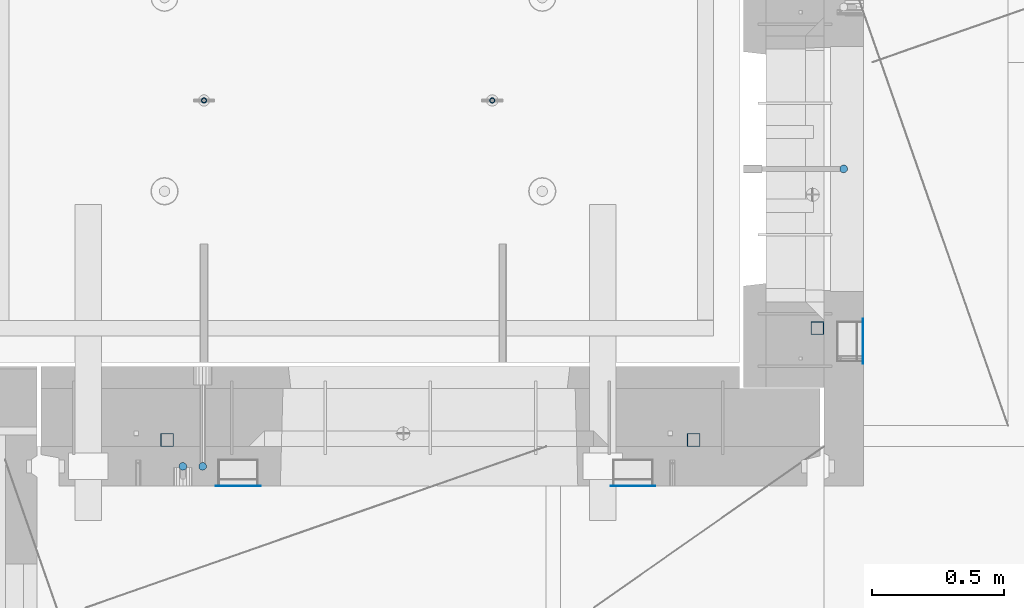
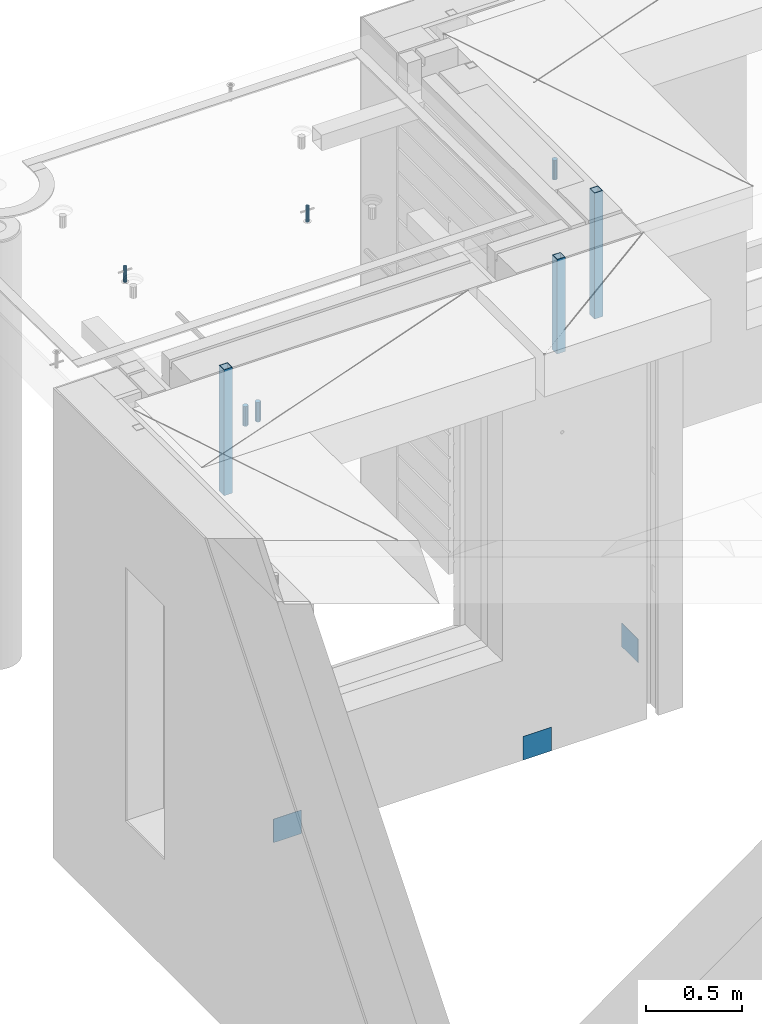
# One storey, part 27 of 352: 11 columns, 11 elements without a shape of their own.
"""IFC2X3 building model written with IfcOpenShell, lengths in millimetres."""

from ifc_helpers import new_model, si_unit, frame, origin_with_axes, place, context, subcontext, project, spatial, faceted_brep, material, type_object, element, aggregate, save


model = new_model("IFC2X3")

# Units and contexts
model_context = context("Model", 3, precision=1e-05, world=origin_with_axes())
body_context = subcontext(model_context, "Body", "Model", "MODEL_VIEW")
ifc_project = project(units=[si_unit("LENGTHUNIT", "METRE", prefix="MILLI"), si_unit("AREAUNIT", "SQUARE_METRE"), si_unit("VOLUMEUNIT", "CUBIC_METRE"), si_unit("MASSUNIT", "GRAM", prefix="KILO"), si_unit("TIMEUNIT", "SECOND"), si_unit("PLANEANGLEUNIT", "RADIAN"), si_unit("SOLIDANGLEUNIT", "STERADIAN"), si_unit("THERMODYNAMICTEMPERATUREUNIT", "DEGREE_CELSIUS"), si_unit("LUMINOUSINTENSITYUNIT", "LUMEN")], contexts=[model_context])

# Site, building, storey
site_placement = place(None, origin_with_axes())
site = spatial("IfcSite", under=ifc_project, at=site_placement, CompositionType="ELEMENT")
building_placement = place(site_placement, origin_with_axes())
building = spatial("IfcBuilding", under=site, at=building_placement, CompositionType="ELEMENT")
storey_placement = place(building_placement, origin_with_axes())
storey = spatial("IfcBuildingStorey", under=building, at=storey_placement, Name="6", CompositionType="ELEMENT", Elevation=0.0)

# Assembly, columns
assembly_1_placement = place(storey_placement, origin_with_axes())
assembly_1 = element("IfcElementAssembly", 1, at=assembly_1_placement, inside=storey, AssemblyPlace="NOTDEFINED", PredefinedType="REINFORCEMENT_UNIT")
ifc_material_1 = material()
column_type_1 = type_object("IfcColumnType", Name="D30", PredefinedType="NOTDEFINED")
column_1_placement = place(assembly_1_placement, frame((8555.00000000836, 20504.9951872276, 99407.5), z_axis=(0.0, 1.0, 0.0), x_axis=(0.0, 0.0, 1.0)))
column_1 = element("IfcColumn", 2, at=column_1_placement, type_object=column_type_1, material=ifc_material_1, ObjectType="D30", context=body_context, shape_type="Brep", body=[
    faceted_brep([(0.0, -15.0, 0.0), (0.0, -12.9903810567666, -7.5), (125.0, -12.9903810567666, -7.5), (125.0, -15.0, 0.0), (0.0, -7.5, -12.9903810567666), (125.0, -7.5, -12.9903810567666), (0.0, 0.0, -15.0), (125.0, 0.0, -15.0), (0.0, 7.5, -12.9903810567666), (125.0, 7.5, -12.9903810567666), (0.0, 12.9903810567666, -7.5), (125.0, 12.9903810567666, -7.5), (0.0, 15.0, 0.0), (125.0, 15.0, 0.0), (0.0, 12.9903810567666, 7.5), (125.0, 12.9903810567666, 7.5), (0.0, 7.5, 12.9903810567666), (125.0, 7.5, 12.9903810567666), (0.0, 0.0, 15.0), (125.0, 0.0, 15.0), (0.0, -7.5, 12.9903810567666), (125.0, -7.5, 12.9903810567666), (0.0, -12.9903810567666, 7.5), (125.0, -12.9903810567666, 7.5)], [[[0, 1, 2, 3]], [[1, 4, 5, 2]], [[4, 6, 7, 5]], [[6, 8, 9, 7]], [[8, 10, 11, 9]], [[10, 12, 13, 11]], [[12, 14, 15, 13]], [[14, 16, 17, 15]], [[16, 18, 19, 17]], [[18, 20, 21, 19]], [[20, 22, 23, 21]], [[22, 0, 3, 23]], [[5, 7, 9, 11, 13, 15, 17, 19, 21, 23, 3, 2]], [[22, 20, 18, 16, 14, 12, 10, 8, 6, 4, 1, 0]]]),
])
column_2_placement = place(assembly_1_placement, frame((8630.00733346229, 20504.9951872205, 99407.5), z_axis=(0.0, -1.0, 0.0), x_axis=(0.0, 0.0, 1.0)))
column_2 = element("IfcColumn", 3, at=column_2_placement, type_object=column_type_1, material=ifc_material_1, ObjectType="D30", context=body_context, shape_type="Brep", body=[
    faceted_brep([(0.0, -15.0, 0.0), (0.0, -12.9903810567666, -7.5), (125.0, -12.9903810567666, -7.5), (125.0, -15.0, 0.0), (0.0, -7.5, -12.9903810567666), (125.0, -7.5, -12.9903810567666), (0.0, 0.0, -15.0), (125.0, 0.0, -15.0), (0.0, 7.5, -12.9903810567666), (125.0, 7.5, -12.9903810567666), (0.0, 12.9903810567666, -7.5), (125.0, 12.9903810567666, -7.5), (0.0, 15.0, 0.0), (125.0, 15.0, 0.0), (0.0, 12.9903810567666, 7.5), (125.0, 12.9903810567666, 7.5), (0.0, 7.5, 12.9903810567666), (125.0, 7.5, 12.9903810567666), (0.0, 0.0, 15.0), (125.0, 0.0, 15.0), (0.0, -7.5, 12.9903810567666), (125.0, -7.5, 12.9903810567666), (0.0, -12.9903810567666, 7.5), (125.0, -12.9903810567666, 7.5)], [[[0, 1, 2, 3]], [[1, 4, 5, 2]], [[4, 6, 7, 5]], [[6, 8, 9, 7]], [[8, 10, 11, 9]], [[10, 12, 13, 11]], [[12, 14, 15, 13]], [[14, 16, 17, 15]], [[16, 18, 19, 17]], [[18, 20, 21, 19]], [[20, 22, 23, 21]], [[22, 0, 3, 23]], [[5, 7, 9, 11, 13, 15, 17, 19, 21, 23, 3, 2]], [[22, 20, 18, 16, 14, 12, 10, 8, 6, 4, 1, 0]]]),
])

# Assembly, column
assembly_2_placement = place(storey_placement, origin_with_axes())
assembly_2 = element("IfcElementAssembly", 4, at=assembly_2_placement, inside=storey, AssemblyPlace="NOTDEFINED", PredefinedType="REINFORCEMENT_UNIT")
column_3_placement = place(assembly_2_placement, frame((11064.9999999907, 21634.9982799657, 99407.5), z_axis=(1.0, 0.0, 0.0), x_axis=(0.0, 0.0, 1.0)))
column_3 = element("IfcColumn", 5, at=column_3_placement, type_object=column_type_1, material=ifc_material_1, ObjectType="D30", context=body_context, shape_type="Brep", body=[
    faceted_brep([(0.0, -15.0, 0.0), (0.0, -12.9903810567666, -7.5), (125.0, -12.9903810567666, -7.5), (125.0, -15.0, 0.0), (0.0, -7.5, -12.9903810567666), (125.0, -7.5, -12.9903810567666), (0.0, 0.0, -15.0), (125.0, 0.0, -15.0), (0.0, 7.5, -12.9903810567666), (125.0, 7.5, -12.9903810567666), (0.0, 12.9903810567666, -7.5), (125.0, 12.9903810567666, -7.5), (0.0, 15.0, 0.0), (125.0, 15.0, 0.0), (0.0, 12.9903810567666, 7.5), (125.0, 12.9903810567666, 7.5), (0.0, 7.5, 12.9903810567666), (125.0, 7.5, 12.9903810567666), (0.0, 0.0, 15.0), (125.0, 0.0, 15.0), (0.0, -7.5, 12.9903810567666), (125.0, -7.5, 12.9903810567666), (0.0, -12.9903810567666, 7.5), (125.0, -12.9903810567666, 7.5)], [[[0, 1, 2, 3]], [[1, 4, 5, 2]], [[4, 6, 7, 5]], [[6, 8, 9, 7]], [[8, 10, 11, 9]], [[10, 12, 13, 11]], [[12, 14, 15, 13]], [[14, 16, 17, 15]], [[16, 18, 19, 17]], [[18, 20, 21, 19]], [[20, 22, 23, 21]], [[22, 0, 3, 23]], [[5, 7, 9, 11, 13, 15, 17, 19, 21, 23, 3, 2]], [[22, 20, 18, 16, 14, 12, 10, 8, 6, 4, 1, 0]]]),
])

assembly_3_placement = place(assembly_1_placement, origin_with_axes())
assembly_3 = element("IfcElementAssembly", 6, at=assembly_3_placement, Name="Steel Assembly", AssemblyPlace="NOTDEFINED", PredefinedType="NOTDEFINED")
ifc_material_2 = material(Name="Undefined")
column_type_2 = type_object("IfcColumnType", PredefinedType="NOTDEFINED")
column_4_placement = place(assembly_3_placement, frame((10265.0, 20430.9951872214, 96755.0), z_axis=(0.0, -1.0, 0.0), x_axis=(0.0, 0.0, 1.0)))
column_4 = element("IfcColumn", 7, at=column_4_placement, type_object=column_type_2, material=ifc_material_2, Name="SPK2", context=body_context, shape_type="Brep", body=[
    faceted_brep([(0.0, 85.0, -1.0), (0.0, 85.0, 1.0), (150.0, 85.0, 1.0), (150.0, 85.0, -1.0), (0.0, -85.0, 1.0), (150.0, -85.0, 1.0), (0.0, -85.0, -1.0), (150.0, -85.0, -1.0)], [[[0, 1, 2, 3]], [[1, 4, 5, 2]], [[4, 6, 7, 5]], [[6, 0, 3, 7]], [[5, 7, 3, 2]], [[6, 4, 1, 0]]]),
])
aggregate(assembly_3, [column_4])

assembly_4_placement = place(assembly_1_placement, origin_with_axes())
assembly_4 = element("IfcElementAssembly", 8, at=assembly_4_placement, Name="Steel Assembly", AssemblyPlace="NOTDEFINED", PredefinedType="NOTDEFINED")
column_5_placement = place(assembly_4_placement, frame((8765.0, 20430.9951872214, 96755.0), z_axis=(0.0, -1.0, 0.0), x_axis=(0.0, 0.0, 1.0)))
column_5 = element("IfcColumn", 9, at=column_5_placement, type_object=column_type_2, material=ifc_material_2, Name="SPK2", context=body_context, shape_type="Brep", body=[
    faceted_brep([(0.0, 85.0, -1.0), (0.0, 85.0, 1.0), (150.0, 85.0, 1.0), (150.0, 85.0, -1.0), (0.0, -85.0, 1.0), (150.0, -85.0, 1.0), (0.0, -85.0, -1.0), (150.0, -85.0, -1.0)], [[[0, 1, 2, 3]], [[1, 4, 5, 2]], [[4, 6, 7, 5]], [[6, 0, 3, 7]], [[5, 7, 3, 2]], [[6, 4, 1, 0]]]),
])
aggregate(assembly_4, [column_5])

assembly_5_placement = place(assembly_2_placement, origin_with_axes())
assembly_5 = element("IfcElementAssembly", 10, at=assembly_5_placement, Name="Steel Assembly", AssemblyPlace="NOTDEFINED", PredefinedType="NOTDEFINED")
column_6_placement = place(assembly_5_placement, frame((11139.0000000031, 20979.9951872276, 96754.9999999969), z_axis=(1.0, 0.0, 0.0), x_axis=(0.0, 0.0, 1.0)))
column_6 = element("IfcColumn", 11, at=column_6_placement, type_object=column_type_2, material=ifc_material_2, Name="SPK2", context=body_context, shape_type="Brep", body=[
    faceted_brep([(0.0, 85.0, -1.0), (0.0, 85.0, 1.0), (150.0, 85.0, 1.0), (150.0, 85.0, -1.0), (0.0, -85.0, 1.0), (150.0, -85.0, 1.0), (0.0, -85.0, -1.0), (150.0, -85.0, -1.0)], [[[0, 1, 2, 3]], [[1, 4, 5, 2]], [[4, 6, 7, 5]], [[6, 0, 3, 7]], [[5, 7, 3, 2]], [[6, 4, 1, 0]]]),
])
aggregate(assembly_5, [column_6])

assembly_6_placement = place(assembly_1_placement, origin_with_axes())
assembly_6 = element("IfcElementAssembly", 12, at=assembly_6_placement, Name="Steel Assembly", AssemblyPlace="NOTDEFINED", PredefinedType="RIGID_FRAME")
ifc_material_3 = material(Name="STEEL/S355J2")
column_type_3 = type_object("IfcColumnType", Name="50X50X3", PredefinedType="NOTDEFINED")
column_7_placement = place(assembly_6_placement, frame((8495.0, 20605.0, 98940.0), z_axis=(1.0, 0.0, 0.0), x_axis=(0.0, 0.0, 1.0)))
column_7 = element("IfcColumn", 13, at=column_7_placement, type_object=column_type_3, material=ifc_material_3, ObjectType="50X50X3", context=body_context, shape_type="Brep", body=[
    faceted_brep([(0.0, 22.0, -22.0), (0.0, -22.0, -22.0), (800.0, -22.0, -22.0), (800.0, 22.0, -22.0), (0.0, -22.0, 22.0), (800.0, -22.0, 22.0), (0.0, 22.0, 22.0), (800.0, 22.0, 22.0), (0.0, 25.0, -25.0), (0.0, 25.0, 25.0), (800.0, 25.0, 25.0), (800.0, 25.0, -25.0), (0.0, -25.0, 25.0), (800.0, -25.0, 25.0), (0.0, -25.0, -25.0), (800.0, -25.0, -25.0)], [[[0, 1, 2, 3]], [[1, 4, 5, 2]], [[4, 6, 7, 5]], [[6, 0, 3, 7]], [[8, 9, 10, 11]], [[9, 12, 13, 10]], [[12, 14, 15, 13]], [[14, 8, 11, 15]], [[13, 15, 11, 10], [5, 7, 3, 2]], [[14, 12, 9, 8], [6, 4, 1, 0]]]),
])
aggregate(assembly_6, [column_7])

# Assembly
assembly_7_placement = place(assembly_1_placement, origin_with_axes())
assembly_7 = element("IfcElementAssembly", 14, at=assembly_7_placement, Name="Steel Assembly", AssemblyPlace="NOTDEFINED", PredefinedType="RIGID_FRAME")

aggregate(assembly_1, [column_1, column_2, assembly_3, assembly_4, assembly_6, assembly_7])

# Column
column_8_placement = place(assembly_7_placement, frame((10495.0, 20605.0, 99140.0), z_axis=(1.0, 0.0, 0.0), x_axis=(0.0, 0.0, 1.0)))
column_8 = element("IfcColumn", 15, at=column_8_placement, type_object=column_type_3, material=ifc_material_3, ObjectType="50X50X3", context=body_context, shape_type="Brep", body=[
    faceted_brep([(0.0, 22.0, -22.0), (0.0, -22.0, -22.0), (600.0, -22.0, -22.0), (600.0, 22.0, -22.0), (0.0, -22.0, 22.0), (600.0, -22.0, 22.0), (0.0, 22.0, 22.0), (600.0, 22.0, 22.0), (0.0, 25.0, -25.0), (0.0, 25.0, 25.0), (600.0, 25.0, 25.0), (600.0, 25.0, -25.0), (0.0, -25.0, 25.0), (600.0, -25.0, 25.0), (0.0, -25.0, -25.0), (600.0, -25.0, -25.0)], [[[0, 1, 2, 3]], [[1, 4, 5, 2]], [[4, 6, 7, 5]], [[6, 0, 3, 7]], [[8, 9, 10, 11]], [[9, 12, 13, 10]], [[12, 14, 15, 13]], [[14, 8, 11, 15]], [[13, 15, 11, 10], [5, 7, 3, 2]], [[14, 12, 9, 8], [6, 4, 1, 0]]]),
])

aggregate(assembly_7, [column_8])

# Assembly
assembly_8_placement = place(assembly_2_placement, origin_with_axes())
assembly_8 = element("IfcElementAssembly", 16, at=assembly_8_placement, Name="Steel Assembly", AssemblyPlace="NOTDEFINED", PredefinedType="RIGID_FRAME")

aggregate(assembly_2, [column_3, assembly_5, assembly_8])

# Column
column_9_placement = place(assembly_8_placement, frame((10965.0, 21030.0, 98940.0), z_axis=(1.0, 0.0, 0.0), x_axis=(0.0, 0.0, 1.0)))
column_9 = element("IfcColumn", 17, at=column_9_placement, type_object=column_type_3, material=ifc_material_3, ObjectType="50X50X3", context=body_context, shape_type="Brep", body=[
    faceted_brep([(0.0, 22.0, -22.0), (0.0, -22.0, -22.0), (800.0, -22.0, -22.0), (800.0, 22.0, -22.0), (0.0, -22.0, 22.0), (800.0, -22.0, 22.0), (0.0, 22.0, 22.0), (800.0, 22.0, 22.0), (0.0, 25.0, -25.0), (0.0, 25.0, 25.0), (800.0, 25.0, 25.0), (800.0, 25.0, -25.0), (0.0, -25.0, 25.0), (800.0, -25.0, 25.0), (0.0, -25.0, -25.0), (800.0, -25.0, -25.0)], [[[0, 1, 2, 3]], [[1, 4, 5, 2]], [[4, 6, 7, 5]], [[6, 0, 3, 7]], [[8, 9, 10, 11]], [[9, 12, 13, 10]], [[12, 14, 15, 13]], [[14, 8, 11, 15]], [[13, 15, 11, 10], [5, 7, 3, 2]], [[14, 12, 9, 8], [6, 4, 1, 0]]]),
])

aggregate(assembly_8, [column_9])

# Assemblies, columns
assembly_9_placement = place(storey_placement, origin_with_axes())
assembly_9 = element("IfcElementAssembly", 18, at=assembly_9_placement, inside=storey, AssemblyPlace="NOTDEFINED", PredefinedType="REINFORCEMENT_UNIT")
assembly_10_placement = place(assembly_9_placement, origin_with_axes())
assembly_10 = element("IfcElementAssembly", 19, at=assembly_10_placement, Name="Steel Assembly", AssemblyPlace="NOTDEFINED", PredefinedType="RIGID_FRAME")
ifc_material_4 = material(Name="STEEL/1.4301")
column_type_4 = type_object("IfcColumnType", PredefinedType="NOTDEFINED")
column_10_placement = place(assembly_10_placement, frame((8634.9865866494, 21895.0212615308, 99444.9999983246), z_axis=(-1.60829999983552e-05, -0.999999999870669, 0.0), x_axis=(0.0, 0.0, 1.0)))
column_10 = element("IfcColumn", 20, at=column_10_placement, type_object=column_type_4, material=ifc_material_4, context=body_context, shape_type="Brep", body=[
    faceted_brep([(0.0, -8.0, 0.0), (0.0, -6.92820323027263, 4.0), (100.000000000029, -6.92820323027263, 4.0), (100.000000000029, -7.99999999999636, 0.0), (0.0, -4.0, 6.92820323027627), (100.000000000029, -4.0, 6.92820323027536), (0.0, 0.0, 8.0), (100.000000000029, 3.63797880709171e-12, 8.0), (0.0, 4.0, 6.92820323027627), (100.000000000029, 4.0, 6.92820323027536), (0.0, 6.92820323027263, 4.0), (100.000000000029, 6.92820323027627, 3.99999999999909), (0.0, 8.0, 0.0), (100.000000000029, 8.0, 0.0), (0.0, 6.92820323027263, -4.0), (100.000000000029, 6.92820323027627, -4.00000000000091), (0.0, 4.0, -6.92820323027627), (100.000000000029, 4.00000000000364, -6.92820323027536), (0.0, 0.0, -8.0), (100.000000000029, 3.63797880709171e-12, -8.00000000000091), (0.0, -4.0, -6.92820323027627), (100.000000000029, -3.99999999999636, -6.92820323027627), (0.0, -6.92820323027263, -4.0), (100.000000000029, -6.92820323027263, -4.0), (0.0, -10.4999999999927, -1.45519152283669e-11), (0.0, -9.09326673972828, -5.25000000001455), (100.000000000262, -9.09326673972828, -5.25000000001455), (100.000000000262, -10.4999999999927, -1.45519152283669e-11), (0.0, -5.24999999998545, -9.09326673974283), (100.000000000262, -5.24999999998545, -9.09326673974283), (0.0, 7.27595761418343e-12, -10.5), (100.000000000262, 7.27595761418343e-12, -10.5), (0.0, 5.25000000001455, -9.09326673975738), (100.000000000262, 5.25000000001455, -9.09326673975738), (0.0, 9.09326673975011, -5.25000000001455), (100.000000000262, 9.09326673975011, -5.25000000001455), (0.0, 10.5000000000073, -1.45519152283669e-11), (100.000000000262, 10.5000000000073, -1.45519152283669e-11), (0.0, 9.09326673975011, 5.25), (100.000000000262, 9.09326673975011, 5.25), (0.0, 5.25000000000728, 9.09326673972828), (100.000000000262, 5.25000000000728, 9.09326673972828), (0.0, 1.45519152283669e-11, 10.4999999999854), (100.000000000262, 1.45519152283669e-11, 10.4999999999854), (0.0, -5.24999999999272, 9.09326673972828), (100.000000000262, -5.24999999999272, 9.09326673972828), (0.0, -9.09326673972828, 5.24999999998545), (100.000000000262, -9.09326673972828, 5.24999999998545)], [[[0, 1, 2, 3]], [[1, 4, 5, 2]], [[4, 6, 7, 5]], [[6, 8, 9, 7]], [[8, 10, 11, 9]], [[10, 12, 13, 11]], [[12, 14, 15, 13]], [[14, 16, 17, 15]], [[16, 18, 19, 17]], [[18, 20, 21, 19]], [[20, 22, 23, 21]], [[22, 0, 3, 23]], [[24, 25, 26, 27]], [[25, 28, 29, 26]], [[28, 30, 31, 29]], [[30, 32, 33, 31]], [[32, 34, 35, 33]], [[34, 36, 37, 35]], [[36, 38, 39, 37]], [[38, 40, 41, 39]], [[40, 42, 43, 41]], [[42, 44, 45, 43]], [[44, 46, 47, 45]], [[46, 24, 27, 47]], [[29, 31, 33, 35, 37, 39, 41, 43, 45, 47, 27, 26], [5, 7, 9, 11, 13, 15, 17, 19, 21, 23, 3, 2]], [[46, 44, 42, 40, 38, 36, 34, 32, 30, 28, 25, 24], [22, 20, 18, 16, 14, 12, 10, 8, 6, 4, 1, 0]]]),
])
aggregate(assembly_10, [column_10])
assembly_11_placement = place(assembly_9_placement, origin_with_axes())
assembly_11 = element("IfcElementAssembly", 21, at=assembly_11_placement, Name="Steel Assembly", AssemblyPlace="NOTDEFINED", PredefinedType="RIGID_FRAME")
aggregate(assembly_9, [assembly_10, assembly_11])
column_11_placement = place(assembly_11_placement, frame((9729.98658651215, 21895.0041915483, 99444.9999983246), z_axis=(-1.60829999983552e-05, -0.999999999870669, 0.0), x_axis=(0.0, 0.0, 1.0)))
column_11 = element("IfcColumn", 22, at=column_11_placement, type_object=column_type_4, material=ifc_material_4, context=body_context, shape_type="Brep", body=[
    faceted_brep([(0.0, -8.0, 0.0), (0.0, -6.92820323027263, 4.0), (100.000000000029, -6.92820323027263, 4.0), (100.000000000029, -7.99999999999636, 0.0), (0.0, -4.0, 6.92820323027627), (100.000000000029, -4.0, 6.92820323027536), (0.0, 0.0, 8.0), (100.000000000029, 3.63797880709171e-12, 8.0), (0.0, 4.0, 6.92820323027627), (100.000000000029, 4.0, 6.92820323027536), (0.0, 6.92820323027263, 4.0), (100.000000000029, 6.92820323027627, 3.99999999999909), (0.0, 8.0, 0.0), (100.000000000029, 8.0, 0.0), (0.0, 6.92820323027263, -4.0), (100.000000000029, 6.92820323027627, -4.00000000000091), (0.0, 4.0, -6.92820323027627), (100.000000000029, 4.00000000000364, -6.92820323027536), (0.0, 0.0, -8.0), (100.000000000029, 3.63797880709171e-12, -8.00000000000091), (0.0, -4.0, -6.92820323027627), (100.000000000029, -3.99999999999636, -6.92820323027627), (0.0, -6.92820323027263, -4.0), (100.000000000029, -6.92820323027263, -4.0), (0.0, -10.4999999999927, -1.45519152283669e-11), (0.0, -9.09326673972828, -5.25000000001455), (100.000000000262, -9.09326673972828, -5.25000000001455), (100.000000000262, -10.4999999999927, -1.45519152283669e-11), (0.0, -5.24999999998545, -9.09326673974283), (100.000000000262, -5.24999999998545, -9.09326673974283), (0.0, 7.27595761418343e-12, -10.5), (100.000000000262, 7.27595761418343e-12, -10.5), (0.0, 5.25000000001455, -9.09326673975738), (100.000000000262, 5.25000000001455, -9.09326673975738), (0.0, 9.09326673975011, -5.25000000001455), (100.000000000262, 9.09326673975011, -5.25000000001455), (0.0, 10.5000000000073, -1.45519152283669e-11), (100.000000000262, 10.5000000000073, -1.45519152283669e-11), (0.0, 9.09326673975011, 5.25), (100.000000000262, 9.09326673975011, 5.25), (0.0, 5.25000000000728, 9.09326673972828), (100.000000000262, 5.25000000000728, 9.09326673972828), (0.0, 1.45519152283669e-11, 10.4999999999854), (100.000000000262, 1.45519152283669e-11, 10.4999999999854), (0.0, -5.24999999999272, 9.09326673972828), (100.000000000262, -5.24999999999272, 9.09326673972828), (0.0, -9.09326673972828, 5.24999999998545), (100.000000000262, -9.09326673972828, 5.24999999998545)], [[[0, 1, 2, 3]], [[1, 4, 5, 2]], [[4, 6, 7, 5]], [[6, 8, 9, 7]], [[8, 10, 11, 9]], [[10, 12, 13, 11]], [[12, 14, 15, 13]], [[14, 16, 17, 15]], [[16, 18, 19, 17]], [[18, 20, 21, 19]], [[20, 22, 23, 21]], [[22, 0, 3, 23]], [[24, 25, 26, 27]], [[25, 28, 29, 26]], [[28, 30, 31, 29]], [[30, 32, 33, 31]], [[32, 34, 35, 33]], [[34, 36, 37, 35]], [[36, 38, 39, 37]], [[38, 40, 41, 39]], [[40, 42, 43, 41]], [[42, 44, 45, 43]], [[44, 46, 47, 45]], [[46, 24, 27, 47]], [[29, 31, 33, 35, 37, 39, 41, 43, 45, 47, 27, 26], [5, 7, 9, 11, 13, 15, 17, 19, 21, 23, 3, 2]], [[46, 44, 42, 40, 38, 36, 34, 32, 30, 28, 25, 24], [22, 20, 18, 16, 14, 12, 10, 8, 6, 4, 1, 0]]]),
])
aggregate(assembly_11, [column_11])

save(model, "model.ifc")
